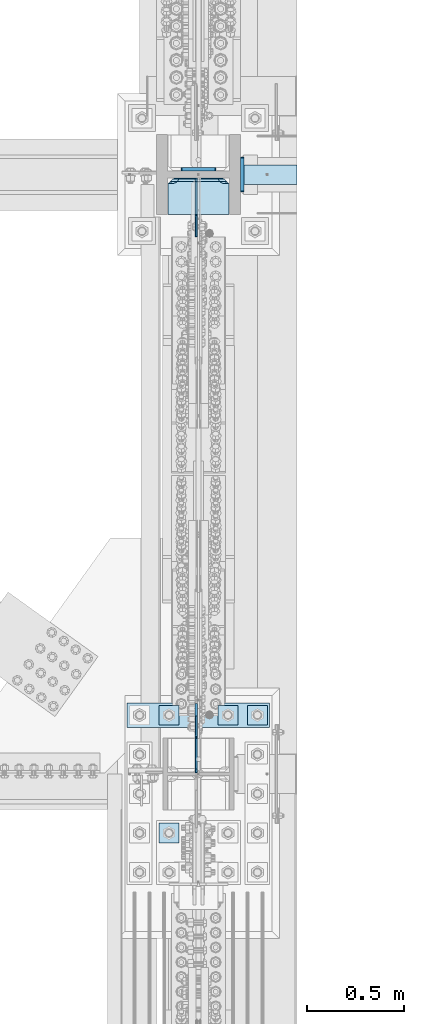
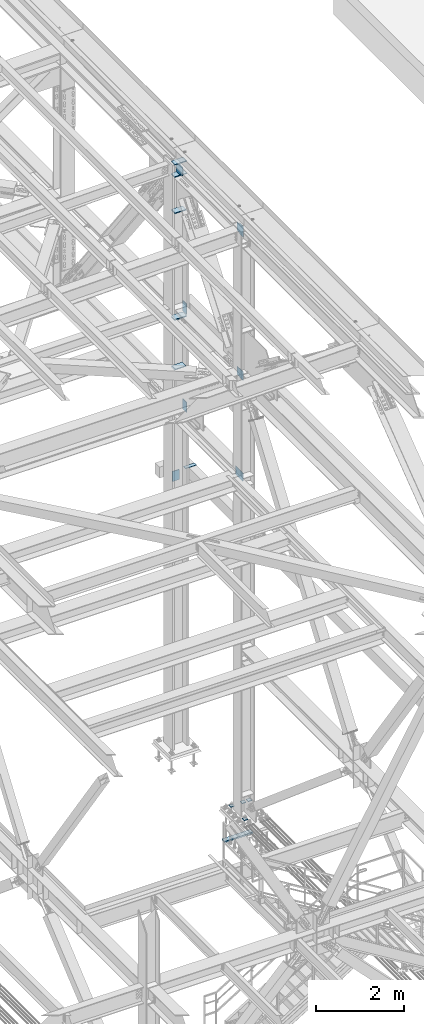
# One storey, part 3583 of 3843: 18 plates, 4 elements without a shape of their own.
"""IFC2X3 building model written with IfcOpenShell, lengths in millimetres."""

from ifc_helpers import new_model, si_unit, frame, origin_with_axes, place, context, subcontext, project, spatial, faceted_brep, material, type_object, element, aggregate, save


model = new_model("IFC2X3")

# Units and contexts
model_context = context("Model", 3, precision=1e-05, world=origin_with_axes())
body_context = subcontext(model_context, "Body", "Model", "MODEL_VIEW")
ifc_project = project(units=[si_unit("LENGTHUNIT", "METRE", prefix="MILLI"), si_unit("AREAUNIT", "SQUARE_METRE"), si_unit("VOLUMEUNIT", "CUBIC_METRE"), si_unit("MASSUNIT", "GRAM", prefix="KILO"), si_unit("TIMEUNIT", "SECOND"), si_unit("PLANEANGLEUNIT", "RADIAN"), si_unit("SOLIDANGLEUNIT", "STERADIAN"), si_unit("THERMODYNAMICTEMPERATUREUNIT", "DEGREE_CELSIUS"), si_unit("LUMINOUSINTENSITYUNIT", "LUMEN")], contexts=[model_context])

# Site, building, storey
site_placement = place(None, origin_with_axes())
site = spatial("IfcSite", under=ifc_project, at=site_placement, CompositionType="ELEMENT")
building_placement = place(site_placement, origin_with_axes())
building = spatial("IfcBuilding", under=site, at=building_placement, Name="Undefined", CompositionType="ELEMENT")
storey_placement = place(building_placement, origin_with_axes())
storey = spatial("IfcBuildingStorey", under=building, at=storey_placement, Name="Undefined", CompositionType="ELEMENT", Elevation=0.0)

# Assembly, plate
assembly_1_placement = place(storey_placement, origin_with_axes())
assembly_1 = element("IfcElementAssembly", 1, at=assembly_1_placement, inside=storey, Name="PLATE", AssemblyPlace="NOTDEFINED", PredefinedType="RIGID_FRAME")
ifc_material = material(Name="STEEL/A572-50")
plate_type_1 = type_object("IfcPlateType", PredefinedType="NOTDEFINED")
plate_1_placement = place(assembly_1_placement, frame((85866.287122492, 28663.8999999998, 37749.1625), z_axis=(0.0, 1.0, 0.0), x_axis=(1.0, 0.0, 0.0)))
plate_1 = element("IfcPlate", 2, at=plate_1_placement, type_object=plate_type_1, material=ifc_material, Name="PLATE", context=body_context, shape_type="Brep", body=[
    faceted_brep([(0.0, -4.76249999999709, 0.0), (-0.000122492027003318, -4.76249999999709, 101.599998474121), (-0.000122492027003318, 4.76249999999709, 101.599998474121), (0.0, 4.76249999999709, 0.0), (290.512755437681, -4.76249999999709, 101.599998474107), (290.512755437681, 4.76249999999709, 101.599998474107), (290.512877507994, -4.76249999999709, -2.91038304567337e-11), (290.512877507994, 4.76249999999709, -2.91038304567337e-11)], [[[0, 1, 2, 3]], [[1, 4, 5, 2]], [[4, 6, 7, 5]], [[6, 0, 3, 7]], [[5, 7, 3, 2]], [[6, 4, 1, 0]]]),
])
aggregate(assembly_1, [plate_1])

# Assembly, plates
assembly_2_placement = place(storey_placement, origin_with_axes())
assembly_2 = element("IfcElementAssembly", 3, at=assembly_2_placement, inside=storey, Name="COLUMN", AssemblyPlace="NOTDEFINED", PredefinedType="RIGID_FRAME")
plate_type_2 = type_object("IfcPlateType", PredefinedType="NOTDEFINED")
plate_2_placement = place(assembly_2_placement, frame((85739.2875, 28742.48125, 37733.2875), z_axis=(0.0, 0.0, -1.0), x_axis=(-1.0, 0.0, 0.0)))
plate_2 = element("IfcPlate", 4, at=plate_2_placement, type_object=plate_type_2, material=ifc_material, Name="PLATE", context=body_context, shape_type="Brep", body=[
    faceted_brep([(-8.22591685395256e-13, -9.52499999999854, 7.9375), (0.0, -9.52499999999418, 274.637500000004), (0.0, 9.52499999999418, 274.637500000004), (0.0, 9.52499999999418, 7.9375), (0.604206210686243, -9.52499999999418, 277.675049744401), (0.604206210686243, 9.52499999999418, 277.675049744401), (2.32483992433117, -9.52499999999418, 280.250160075673), (2.32483992433117, 9.52499999999418, 280.250160075673), (4.8999502555962, -9.52499999999418, 281.970793789311), (4.8999502555962, 9.52499999999418, 281.970793789311), (7.9375, -9.52499999999418, 282.575000000004), (7.9375, 9.52499999999418, 282.575000000004), (173.037499999991, -9.52499999999418, 282.575000000004), (173.037499999991, 9.52499999999418, 282.575000000004), (176.075049744395, -9.52499999999418, 281.970793789311), (176.075049744395, 9.52499999999418, 281.970793789311), (178.65016007566, -9.52499999999418, 280.250160075673), (178.65016007566, 9.52499999999418, 280.250160075673), (180.370793789305, -9.52499999999418, 277.675049744401), (180.370793789305, 9.52499999999418, 277.675049744401), (180.974999999991, -9.52499999999418, 274.637500000004), (180.974999999991, 9.52499999999418, 274.637500000004), (180.974999999991, -9.52499999999418, 7.93750000000728), (180.974999999991, 9.52499999999418, 7.93750000000728), (180.370793789305, -9.52499999999418, 4.89995025561075), (180.370793789305, 9.52499999999418, 4.89995025561075), (178.65016007566, -9.52499999999418, 2.32483992433845), (178.65016007566, 9.52499999999418, 2.32483992433845), (176.075049744395, -9.52499999999418, 0.604206210700795), (176.075049744395, 9.52499999999418, 0.604206210700795), (173.037500000006, -9.52499999999418, 7.27595761418343e-12), (173.037500000006, 9.52499999999418, 7.27595761418343e-12), (7.9375, -9.52499999999854, 0.0), (7.9375, 9.52499999999418, 0.0), (4.8999502555962, -9.52499999999418, 0.604206210693519), (4.8999502555962, 9.52499999999418, 0.604206210693519), (2.32483992433117, -9.52499999999418, 2.32483992433117), (2.32483992433117, 9.52499999999418, 2.32483992433117), (0.604206210686243, -9.52499999999418, 4.89995025560347), (0.604206210686243, 9.52499999999418, 4.89995025560347)], [[[0, 1, 2, 3]], [[1, 4, 5, 2]], [[4, 6, 7, 5]], [[6, 8, 9, 7]], [[8, 10, 11, 9]], [[10, 12, 13, 11]], [[12, 14, 15, 13]], [[14, 16, 17, 15]], [[16, 18, 19, 17]], [[18, 20, 21, 19]], [[20, 22, 23, 21]], [[22, 24, 25, 23]], [[24, 26, 27, 25]], [[26, 28, 29, 27]], [[28, 30, 31, 29]], [[30, 32, 33, 31]], [[32, 34, 35, 33]], [[34, 36, 37, 35]], [[36, 38, 39, 37]], [[38, 0, 3, 39]], [[5, 7, 9, 11, 13, 15, 17, 19, 21, 23, 25, 27, 29, 31, 33, 35, 37, 39, 3, 2]], [[38, 36, 34, 32, 30, 28, 26, 24, 22, 20, 18, 16, 14, 12, 10, 8, 6, 4, 1, 0]]]),
])
plate_3_placement = place(assembly_2_placement, frame((85875.8124999523, 28805.1875, 39619.2375), z_axis=(0.0, 0.0, -1.0), x_axis=(0.0, -1.0, 0.0)))
plate_3 = element("IfcPlate", 5, at=plate_3_placement, type_object=plate_type_2, material=ifc_material, Name="PLATE", context=body_context, shape_type="Brep", body=[
    faceted_brep([(-8.22591685395256e-13, -9.52499999999854, 7.9375), (0.0, -9.52499999999418, 274.637500000004), (0.0, 9.52499999999418, 274.637500000004), (0.0, 9.52499999999418, 7.9375), (0.604206210686243, -9.52499999999418, 277.675049744401), (0.604206210686243, 9.52499999999418, 277.675049744401), (2.32483992433117, -9.52499999999418, 280.250160075673), (2.32483992433117, 9.52499999999418, 280.250160075673), (4.8999502555962, -9.52499999999418, 281.970793789311), (4.8999502555962, 9.52499999999418, 281.970793789311), (7.9375, -9.52499999999418, 282.575000000004), (7.9375, 9.52499999999418, 282.575000000004), (173.037499999991, -9.52499999999418, 282.575000000004), (173.037499999991, 9.52499999999418, 282.575000000004), (176.075049744395, -9.52499999999418, 281.970793789311), (176.075049744395, 9.52499999999418, 281.970793789311), (178.65016007566, -9.52499999999418, 280.250160075673), (178.65016007566, 9.52499999999418, 280.250160075673), (180.370793789305, -9.52499999999418, 277.675049744401), (180.370793789305, 9.52499999999418, 277.675049744401), (180.974999999991, -9.52499999999418, 274.637500000004), (180.974999999991, 9.52499999999418, 274.637500000004), (180.974999999991, -9.52499999999418, 7.93750000000728), (180.974999999991, 9.52499999999418, 7.93750000000728), (180.370793789305, -9.52499999999418, 4.89995025561075), (180.370793789305, 9.52499999999418, 4.89995025561075), (178.65016007566, -9.52499999999418, 2.32483992433845), (178.65016007566, 9.52499999999418, 2.32483992433845), (176.075049744395, -9.52499999999418, 0.604206210700795), (176.075049744395, 9.52499999999418, 0.604206210700795), (173.037500000006, -9.52499999999418, 7.27595761418343e-12), (173.037500000006, 9.52499999999418, 7.27595761418343e-12), (7.9375, -9.52499999999854, 0.0), (7.9375, 9.52499999999418, 0.0), (4.8999502555962, -9.52499999999418, 0.604206210693519), (4.8999502555962, 9.52499999999418, 0.604206210693519), (2.32483992433117, -9.52499999999418, 2.32483992433117), (2.32483992433117, 9.52499999999418, 2.32483992433117), (0.604206210686243, -9.52499999999418, 4.89995025560347), (0.604206210686243, 9.52499999999418, 4.89995025560347)], [[[0, 1, 2, 3]], [[1, 4, 5, 2]], [[4, 6, 7, 5]], [[6, 8, 9, 7]], [[8, 10, 11, 9]], [[10, 12, 13, 11]], [[12, 14, 15, 13]], [[14, 16, 17, 15]], [[16, 18, 19, 17]], [[18, 20, 21, 19]], [[20, 22, 23, 21]], [[22, 24, 25, 23]], [[24, 26, 27, 25]], [[26, 28, 29, 27]], [[28, 30, 31, 29]], [[30, 32, 33, 31]], [[32, 34, 35, 33]], [[34, 36, 37, 35]], [[36, 38, 39, 37]], [[38, 0, 3, 39]], [[5, 7, 9, 11, 13, 15, 17, 19, 21, 23, 25, 27, 29, 31, 33, 35, 37, 39, 3, 2]], [[38, 36, 34, 32, 30, 28, 26, 24, 22, 20, 18, 16, 14, 12, 10, 8, 6, 4, 1, 0]]]),
])
plate_4_placement = place(assembly_2_placement, frame((85875.8124999523, 28805.1875, 42356.0875), z_axis=(0.0, 0.0, -1.0), x_axis=(0.0, -1.0, 0.0)))
plate_4 = element("IfcPlate", 6, at=plate_4_placement, type_object=plate_type_2, material=ifc_material, Name="PLATE", context=body_context, shape_type="Brep", body=[
    faceted_brep([(-8.22591685395256e-13, -9.52499999999854, 7.9375), (0.0, -9.52499999999418, 274.637500000004), (0.0, 9.52499999999418, 274.637500000004), (0.0, 9.52499999999418, 7.9375), (0.604206210686243, -9.52499999999418, 277.675049744401), (0.604206210686243, 9.52499999999418, 277.675049744401), (2.32483992433117, -9.52499999999418, 280.250160075673), (2.32483992433117, 9.52499999999418, 280.250160075673), (4.8999502555962, -9.52499999999418, 281.970793789311), (4.8999502555962, 9.52499999999418, 281.970793789311), (7.9375, -9.52499999999418, 282.575000000004), (7.9375, 9.52499999999418, 282.575000000004), (173.037499999991, -9.52499999999418, 282.575000000004), (173.037499999991, 9.52499999999418, 282.575000000004), (176.075049744395, -9.52499999999418, 281.970793789311), (176.075049744395, 9.52499999999418, 281.970793789311), (178.65016007566, -9.52499999999418, 280.250160075673), (178.65016007566, 9.52499999999418, 280.250160075673), (180.370793789305, -9.52499999999418, 277.675049744401), (180.370793789305, 9.52499999999418, 277.675049744401), (180.974999999991, -9.52499999999418, 274.637500000004), (180.974999999991, 9.52499999999418, 274.637500000004), (180.974999999991, -9.52499999999418, 7.93750000000728), (180.974999999991, 9.52499999999418, 7.93750000000728), (180.370793789305, -9.52499999999418, 4.89995025561075), (180.370793789305, 9.52499999999418, 4.89995025561075), (178.65016007566, -9.52499999999418, 2.32483992433845), (178.65016007566, 9.52499999999418, 2.32483992433845), (176.075049744395, -9.52499999999418, 0.604206210700795), (176.075049744395, 9.52499999999418, 0.604206210700795), (173.037500000006, -9.52499999999418, 7.27595761418343e-12), (173.037500000006, 9.52499999999418, 7.27595761418343e-12), (7.9375, -9.52499999999854, 0.0), (7.9375, 9.52499999999418, 0.0), (4.8999502555962, -9.52499999999418, 0.604206210693519), (4.8999502555962, 9.52499999999418, 0.604206210693519), (2.32483992433117, -9.52499999999418, 2.32483992433117), (2.32483992433117, 9.52499999999418, 2.32483992433117), (0.604206210686243, -9.52499999999418, 4.89995025560347), (0.604206210686243, 9.52499999999418, 4.89995025560347)], [[[0, 1, 2, 3]], [[1, 4, 5, 2]], [[4, 6, 7, 5]], [[6, 8, 9, 7]], [[8, 10, 11, 9]], [[10, 12, 13, 11]], [[12, 14, 15, 13]], [[14, 16, 17, 15]], [[16, 18, 19, 17]], [[18, 20, 21, 19]], [[20, 22, 23, 21]], [[22, 24, 25, 23]], [[24, 26, 27, 25]], [[26, 28, 29, 27]], [[28, 30, 31, 29]], [[30, 32, 33, 31]], [[32, 34, 35, 33]], [[34, 36, 37, 35]], [[36, 38, 39, 37]], [[38, 0, 3, 39]], [[5, 7, 9, 11, 13, 15, 17, 19, 21, 23, 25, 27, 29, 31, 33, 35, 37, 39, 3, 2]], [[38, 36, 34, 32, 30, 28, 26, 24, 22, 20, 18, 16, 14, 12, 10, 8, 6, 4, 1, 0]]]),
])
plate_type_3 = type_object("IfcPlateType", PredefinedType="NOTDEFINED")
plate_5_placement = place(assembly_2_placement, frame((85809.1375, 28509.1188, 40731.5069065225), z_axis=(-1.0, 0.0, 0.0), x_axis=(0.0, 1.0, 0.0)))
plate_5 = element("IfcPlate", 7, at=plate_5_placement, type_object=plate_type_3, material=ifc_material, Name="PLATE", context=body_context, shape_type="Brep", body=[
    faceted_brep([(0.0, -12.6999999999971, 302.835803430513), (0.0, 12.6999999999971, 317.500500047681), (0.0, 12.6999999999971, 3.17549995231093), (0.0, -12.6999999999971, 17.8401965694793), (158.749449952324, 12.6999999999971, 317.500500047681), (184.150200047683, 12.6999999999971, 292.099749952322), (184.150200047683, 12.6999999999971, 28.575250047681), (158.750449952313, 12.6999999999971, 3.17549995231093), (171.450325014754, -9.29682918828621, 15.8753750147443), (169.485503430507, -12.6999999999971, 17.8401965694793), (169.485503430507, -12.6999999999971, 302.835803430513), (171.449825014755, -9.29769521368144, 304.800124985253)], [[[0, 1, 2, 3]], [[4, 5, 6, 7, 2, 1]], [[3, 2, 7, 8, 9]], [[0, 3, 9, 10]], [[4, 1, 0, 10, 11]], [[4, 11, 5]], [[10, 9, 8, 6, 5, 11]], [[7, 6, 8]]]),
])
plate_6_placement = place(assembly_2_placement, frame((85490.05, 28509.11875, 46101.0), z_axis=(1.0, 0.0, 0.0), x_axis=(0.0, 1.0, 0.0)))
plate_6 = element("IfcPlate", 8, at=plate_6_placement, type_object=plate_type_3, material=ifc_material, Name="PLATE", context=body_context, shape_type="Brep", body=[
    faceted_brep([(171.462145952202, 9.27600831387099, 50.4083462814015), (169.485303430512, 12.6999999999971, 48.4315037597116), (169.485303430512, 12.6999999999971, 269.068496240288), (171.462145952202, 9.27600831387099, 267.091653718599), (178.985404100069, -3.75465703669033, 263.258362229142), (184.150000047688, -12.6999999999971, 262.440370590484), (184.150000047688, -12.6999999999971, 55.0596294095158), (178.985404100069, -3.75465703669033, 54.2416377708578), (0.0, -12.6999999999971, 0.0), (0.0, -12.7000000020344, 317.500000001608), (0.0, 12.6999999977998, 317.500000001586), (0.0, 12.6999999999971, 0.0), (160.33750076294, -12.6999999999971, 317.5), (160.33750076294, 12.6999999999971, 317.5), (160.33750076294, -12.6999999999971, 288.924999237061), (160.33750076294, 12.6999999999971, 288.924999237061), (161.658362992082, -12.6999999999971, 280.585403337129), (161.658362992082, 12.6999999999971, 280.585403337129), (165.491654481539, -12.6999999999971, 273.062145189266), (165.491654481539, 12.6999999999971, 273.062145189266), (171.462145952202, -12.6999999999971, 267.091653718599), (178.985404100069, -12.6999999999971, 263.258362229142), (178.985404100069, -12.6999999999971, 54.2416377708578), (171.462145952202, -12.6999999999971, 50.4083462814015), (165.491654481539, -12.6999999999971, 44.4378548107343), (165.491654481539, 12.6999999999971, 44.4378548107343), (161.658362992082, -12.6999999999971, 36.9145966628712), (161.658362992082, 12.6999999999971, 36.9145966628712), (160.33750076294, -12.6999999999971, 28.5750007629395), (160.33750076294, 12.6999999999971, 28.5750007629395), (160.33750076294, -12.6999999999971, 0.0), (160.33750076294, 12.6999999999971, 0.0)], [[[0, 1, 2, 3, 4, 5, 6, 7]], [[8, 9, 10, 11]], [[9, 12, 13, 10]], [[12, 14, 15, 13]], [[14, 16, 17, 15]], [[16, 18, 19, 17]], [[19, 18, 20, 3, 2]], [[20, 21, 4, 3]], [[21, 5, 4]], [[22, 7, 6]], [[22, 23, 0, 7]], [[23, 24, 25, 1, 0]], [[24, 26, 27, 25]], [[26, 28, 29, 27]], [[28, 30, 31, 29]], [[30, 8, 11, 31]], [[25, 27, 29, 31, 11, 10, 13, 15, 17, 19, 2, 1]], [[30, 28, 26, 24, 23, 22, 6, 5, 21, 20, 18, 16, 14, 12, 9, 8]]]),
])
plate_7_placement = place(assembly_2_placement, frame((85809.1375, 28509.1188, 45089.9791498074), z_axis=(-1.0, 0.0, 0.0), x_axis=(0.0, 1.0, 0.0)))
plate_7 = element("IfcPlate", 9, at=plate_7_placement, type_object=plate_type_3, material=ifc_material, Name="PLATE", context=body_context, shape_type="Brep", body=[
    faceted_brep([(0.0, -12.6999999999971, 302.835803430513), (0.0, 12.6999999999971, 317.500500047681), (0.0, 12.6999999999971, 3.17549995231093), (0.0, -12.6999999999971, 17.8401965694793), (158.749449952324, 12.6999999999971, 317.500500047681), (184.150200047683, 12.6999999999971, 292.099749952322), (184.150200047683, 12.6999999999971, 28.575250047681), (158.750449952313, 12.6999999999971, 3.17549995231093), (171.450325014754, -9.29682918828621, 15.8753750147443), (169.485503430507, -12.6999999999971, 17.8401965694793), (169.485503430507, -12.6999999999971, 302.835803430513), (171.449825014755, -9.29769521368144, 304.800124985253)], [[[0, 1, 2, 3]], [[4, 5, 6, 7, 2, 1]], [[3, 2, 7, 8, 9]], [[0, 3, 9, 10]], [[4, 1, 0, 10, 11]], [[4, 11, 5]], [[10, 9, 8, 6, 5, 11]], [[7, 6, 8]]]),
])
plate_8_placement = place(assembly_2_placement, frame((85490.05, 28509.11875, 46443.9), z_axis=(1.0, 0.0, 0.0), x_axis=(0.0, 1.0, 0.0)))
plate_8 = element("IfcPlate", 10, at=plate_8_placement, type_object=plate_type_3, material=ifc_material, Name="PLATE", context=body_context, shape_type="Brep", body=[
    faceted_brep([(171.462145952202, 9.27600831387099, 50.4083462814015), (169.485303430512, 12.6999999999971, 48.4315037597116), (169.485303430512, 12.6999999999971, 269.068496240288), (171.462145952202, 9.27600831387099, 267.091653718599), (178.985404100069, -3.75465703669033, 263.258362229142), (184.150000047688, -12.6999999999971, 262.440370590484), (184.150000047688, -12.6999999999971, 55.0596294095158), (178.985404100069, -3.75465703669033, 54.2416377708578), (0.0, -12.6999999999971, 0.0), (0.0, -12.7000000020344, 317.500000001608), (0.0, 12.6999999977998, 317.500000001586), (0.0, 12.6999999999971, 0.0), (160.33750076294, -12.6999999999971, 317.5), (160.33750076294, 12.6999999999971, 317.5), (160.33750076294, -12.6999999999971, 288.924999237061), (160.33750076294, 12.6999999999971, 288.924999237061), (161.658362992082, -12.6999999999971, 280.585403337129), (161.658362992082, 12.6999999999971, 280.585403337129), (165.491654481539, -12.6999999999971, 273.062145189266), (165.491654481539, 12.6999999999971, 273.062145189266), (171.462145952202, -12.6999999999971, 267.091653718599), (178.985404100069, -12.6999999999971, 263.258362229142), (178.985404100069, -12.6999999999971, 54.2416377708578), (171.462145952202, -12.6999999999971, 50.4083462814015), (165.491654481539, -12.6999999999971, 44.4378548107343), (165.491654481539, 12.6999999999971, 44.4378548107343), (161.658362992082, -12.6999999999971, 36.9145966628712), (161.658362992082, 12.6999999999971, 36.9145966628712), (160.33750076294, -12.6999999999971, 28.5750007629395), (160.33750076294, 12.6999999999971, 28.5750007629395), (160.33750076294, -12.6999999999971, 0.0), (160.33750076294, 12.6999999999971, 0.0)], [[[0, 1, 2, 3, 4, 5, 6, 7]], [[8, 9, 10, 11]], [[9, 12, 13, 10]], [[12, 14, 15, 13]], [[14, 16, 17, 15]], [[16, 18, 19, 17]], [[19, 18, 20, 3, 2]], [[20, 21, 4, 3]], [[21, 5, 4]], [[22, 7, 6]], [[22, 23, 0, 7]], [[23, 24, 25, 1, 0]], [[24, 26, 27, 25]], [[26, 28, 29, 27]], [[28, 30, 31, 29]], [[30, 8, 11, 31]], [[25, 27, 29, 31, 11, 10, 13, 15, 17, 19, 2, 1]], [[30, 28, 26, 24, 23, 22, 6, 5, 21, 20, 18, 16, 14, 12, 9, 8]]]),
])
plate_type_4 = type_object("IfcPlateType", PredefinedType="NOTDEFINED")
plate_9_placement = place(assembly_2_placement, frame((85490.05, 28512.29375, 42116.375), z_axis=(1.0, 0.0, 0.0), x_axis=(0.0, 1.0, 0.0)))
plate_9 = element("IfcPlate", 11, at=plate_9_placement, type_object=plate_type_4, material=ifc_material, Name="PLATE", context=body_context, shape_type="Brep", body=[
    faceted_brep([(0.0, -15.875, 0.0), (0.0, -15.875, 317.5), (0.0, 15.875, 317.5), (0.0, 15.875, 0.0), (150.812498468062, -15.8749999998181, 317.5), (150.812498468251, 15.8750000001601, 317.5), (184.149999995119, -15.8749999997817, 284.162498474121), (184.149999995323, 15.8750000001965, 284.162498474121), (184.150000002424, -15.8749999997744, 33.3375015258789), (184.150000002628, 15.8750000001892, 33.3375015258789), (150.812498477302, -15.8749999998181, 0.0), (150.812498477491, 15.8750000001528, 0.0)], [[[0, 1, 2, 3]], [[1, 4, 5, 2]], [[4, 6, 7, 5]], [[6, 8, 9, 7]], [[8, 10, 11, 9]], [[10, 0, 3, 11]], [[5, 7, 9, 11, 3, 2]], [[10, 8, 6, 4, 1, 0]]]),
])

assembly_3_placement = place(storey_placement, origin_with_axes())
assembly_3 = element("IfcElementAssembly", 12, at=assembly_3_placement, inside=storey, Name="TEMPLATE", AssemblyPlace="NOTDEFINED", PredefinedType="RIGID_FRAME")
plate_type_5 = type_object("IfcPlateType", PredefinedType="NOTDEFINED")
plate_10_placement = place(assembly_3_placement, frame((85902.8, 25971.5, 30143.45), z_axis=(0.0, -1.0, 0.0), x_axis=(1.0, 0.0, 0.0)))
plate_10 = element("IfcPlate", 13, at=plate_10_placement, type_object=plate_type_5, material=ifc_material, Name="Washer Plate", context=body_context, shape_type="Brep", body=[
    faceted_brep([(0.0, -6.3499999046162, 0.0), (-1.67347025126219e-10, -6.35000000000582, 101.600000000151), (-1.67347025126219e-10, 6.35000000000582, 101.600000000151), (7.27595761418343e-12, 6.3499999046162, 0.0), (101.599998474121, -6.34999999999854, 101.599998474121), (101.599998474121, 6.34999999999854, 101.599998474121), (101.6, -6.34999999999854, 0.0), (101.6, 6.34999999999854, 0.0)], [[[0, 1, 2, 3]], [[1, 4, 5, 2]], [[4, 6, 7, 5]], [[6, 0, 3, 7]], [[5, 7, 3, 2]], [[6, 4, 1, 0]]]),
])
plate_11_placement = place(assembly_3_placement, frame((85750.4, 25971.5, 30143.45), z_axis=(0.0, -1.0, 0.0), x_axis=(1.0, 0.0, 0.0)))
plate_11 = element("IfcPlate", 14, at=plate_11_placement, type_object=plate_type_5, material=ifc_material, Name="Washer Plate", context=body_context, shape_type="Brep", body=[
    faceted_brep([(0.0, -6.3499999046162, 0.0), (-1.67347025126219e-10, -6.35000000000582, 101.600000000151), (-1.67347025126219e-10, 6.35000000000582, 101.600000000151), (7.27595761418343e-12, 6.3499999046162, 0.0), (101.599998474121, -6.34999999999854, 101.599998474121), (101.599998474121, 6.34999999999854, 101.599998474121), (101.6, -6.34999999999854, 0.0), (101.6, 6.34999999999854, 0.0)], [[[0, 1, 2, 3]], [[1, 4, 5, 2]], [[4, 6, 7, 5]], [[6, 0, 3, 7]], [[5, 7, 3, 2]], [[6, 4, 1, 0]]]),
])
plate_12_placement = place(assembly_3_placement, frame((85445.6, 25361.9, 30143.45), z_axis=(0.0, -1.0, 0.0), x_axis=(1.0, 0.0, 0.0)))
plate_12 = element("IfcPlate", 15, at=plate_12_placement, type_object=plate_type_5, material=ifc_material, Name="Washer Plate", context=body_context, shape_type="Brep", body=[
    faceted_brep([(0.0, -6.3499999046162, 0.0), (-1.67347025126219e-10, -6.35000000000582, 101.600000000151), (-1.67347025126219e-10, 6.35000000000582, 101.600000000151), (7.27595761418343e-12, 6.3499999046162, 0.0), (101.599998474121, -6.34999999999854, 101.599998474121), (101.599998474121, 6.34999999999854, 101.599998474121), (101.6, -6.34999999999854, 0.0), (101.6, 6.34999999999854, 0.0)], [[[0, 1, 2, 3]], [[1, 4, 5, 2]], [[4, 6, 7, 5]], [[6, 0, 3, 7]], [[5, 7, 3, 2]], [[6, 4, 1, 0]]]),
])
plate_13_placement = place(assembly_3_placement, frame((85445.6, 25971.5, 30143.45), z_axis=(0.0, -1.0, 0.0), x_axis=(1.0, 0.0, 0.0)))
plate_13 = element("IfcPlate", 16, at=plate_13_placement, type_object=plate_type_5, material=ifc_material, Name="Washer Plate", context=body_context, shape_type="Brep", body=[
    faceted_brep([(0.0, -6.3499999046162, 0.0), (-1.67347025126219e-10, -6.35000000000582, 101.600000000151), (-1.67347025126219e-10, 6.35000000000582, 101.600000000151), (7.27595761418343e-12, 6.3499999046162, 0.0), (101.599998474121, -6.34999999999854, 101.599998474121), (101.599998474121, 6.34999999999854, 101.599998474121), (101.6, -6.34999999999854, 0.0), (101.6, 6.34999999999854, 0.0)], [[[0, 1, 2, 3]], [[1, 4, 5, 2]], [[4, 6, 7, 5]], [[6, 0, 3, 7]], [[5, 7, 3, 2]], [[6, 4, 1, 0]]]),
])

assembly_4_placement = place(storey_placement, origin_with_axes())
assembly_4 = element("IfcElementAssembly", 17, at=assembly_4_placement, inside=storey, Name="COLUMN", AssemblyPlace="NOTDEFINED", PredefinedType="RIGID_FRAME")
plate_type_6 = type_object("IfcPlateType", PredefinedType="NOTDEFINED")
plate_14_placement = place(assembly_4_placement, frame((85637.6870000839, 25623.04375, 42138.6), z_axis=(0.0, 0.707106781186548, 0.707106781186548), x_axis=(5.70000238222118e-08, 0.707106781186546, -0.707106781186546)))
plate_14 = element("IfcPlate", 18, at=plate_14_placement, type_object=plate_type_6, material=ifc_material, Name="PLATE", context=body_context, shape_type="Brep", body=[
    faceted_brep([(0.0, -4.76249999999709, 0.0), (-152.664354057442, -4.76249999999709, 152.66435405743), (-152.664354057442, 4.76249999999709, 152.66435405743), (0.0, 4.76249999999709, 0.0), (-152.664354057319, -4.76249999999709, 179.605122420653), (-152.664354057319, 4.76249999999709, 179.605122420653), (-40.4111524084819, -4.76249999999709, 291.858323799781), (-40.4111524084819, 4.76249999999709, 291.858323799781), (-36.2909759403356, -4.76249999999709, 289.105309899307), (-36.2909759403356, 4.76249999999709, 289.105309899307), (-31.4308964223037, -4.76249999999709, 288.138579976723), (-31.4308964223037, 4.76249999999709, 288.138579976723), (-26.5708169042682, -4.76249999999709, 289.105309899314), (-26.5708169042682, 4.76249999999709, 289.105309899314), (-22.4506404361291, -4.76249999999709, 291.858323799781), (-22.4506404361291, 4.76249999999709, 291.858323799781), (49.9526746753309, -4.76249999999709, 364.261638911237), (49.9526746753309, 4.76249999999709, 364.261638911237), (211.597284853791, -4.76249999999709, 202.61702873277), (211.597284853791, 4.76249999999709, 202.61702873277), (139.193969742335, -4.76249999999709, 130.213713621313), (139.193969742335, 4.76249999999709, 130.213713621313), (136.440955841861, -4.76249999999709, 126.093537153181), (136.440955841861, 4.76249999999709, 126.093537153181), (135.474225919277, -4.76249999999709, 121.233457635142), (135.474225919277, 4.76249999999709, 121.233457635142), (136.440955841865, -4.76249999999709, 116.373378117103), (136.440955841865, 4.76249999999709, 116.373378117103), (139.193969877184, -4.76249999999709, 112.253201514119), (139.193969877184, 4.76249999999709, 112.253201514119), (26.9407683631998, -4.76249999999709, 1.30967237055302e-10), (26.9407683631998, 4.76249999999709, 1.30967237055302e-10)], [[[0, 1, 2, 3]], [[1, 4, 5, 2]], [[4, 6, 7, 5]], [[6, 8, 9, 7]], [[8, 10, 11, 9]], [[10, 12, 13, 11]], [[12, 14, 15, 13]], [[14, 16, 17, 15]], [[16, 18, 19, 17]], [[18, 20, 21, 19]], [[20, 22, 23, 21]], [[22, 24, 25, 23]], [[24, 26, 27, 25]], [[26, 28, 29, 27]], [[28, 30, 31, 29]], [[30, 0, 3, 31]], [[5, 7, 9, 11, 13, 15, 17, 19, 21, 23, 25, 27, 29, 31, 3, 2]], [[30, 28, 26, 24, 22, 20, 18, 16, 14, 12, 10, 8, 6, 4, 1, 0]]]),
])
plate_type_7 = type_object("IfcPlateType", PredefinedType="NOTDEFINED")
plate_15_placement = place(assembly_4_placement, frame((85636.1, 25623.04375, 39331.9), z_axis=(0.0, 0.707106781186548, 0.707106781186548), x_axis=(5.70000238222118e-08, 0.707106781186546, -0.707106781186546)))
plate_15 = element("IfcPlate", 19, at=plate_15_placement, type_object=plate_type_7, material=ifc_material, Name="PLATE", context=body_context, shape_type="Brep", body=[
    faceted_brep([(0.0, -6.3499999046162, 0.0), (-134.703841815397, -6.35000000000582, 134.703841815395), (-134.703841815397, 6.35000000000582, 134.703841815395), (7.27595761418343e-12, 6.3499999046162, 0.0), (-134.703841815259, -6.35000000000582, 161.644610178604), (-134.703841815259, 6.35000000000582, 161.644610178604), (103.834211404464, -6.35000000000582, 400.182663398424), (103.834211404464, 6.35000000000582, 400.182663398424), (265.478821582976, -6.35000000000582, 238.538053219985), (265.478821582976, 6.35000000000582, 238.538053219985), (26.9407683632217, -6.34999999999854, 1.30967237055302e-10), (26.9407683632217, 6.34999999999854, 1.30967237055302e-10)], [[[0, 1, 2, 3]], [[1, 4, 5, 2]], [[4, 6, 7, 5]], [[6, 8, 9, 7]], [[8, 10, 11, 9]], [[10, 0, 3, 11]], [[5, 7, 9, 11, 3, 2]], [[10, 8, 6, 4, 1, 0]]]),
])

# Plate
plate_type_8 = type_object("IfcPlateType", PredefinedType="NOTDEFINED")
plate_16_placement = place(assembly_2_placement, frame((85636.8932500839, 28696.44375, 46132.75), z_axis=(0.0, -0.707106781186682, 0.707106781186413), x_axis=(0.0, -0.707106781186548, -0.707106781186548)))
plate_16 = element("IfcPlate", 20, at=plate_16_placement, type_object=plate_type_8, material=ifc_material, Name="PLATE", context=body_context, shape_type="Brep", body=[
    faceted_brep([(0.0, -4.76249999999709, 0.0), (-197.565634662584, -4.76249999999709, 197.565634662576), (-197.565634662584, 4.76249999999709, 197.565634662576), (0.0, 4.76249999999709, 0.0), (-197.565634662438, -4.76249999999709, 224.5064030258), (-197.565634662438, 4.76249999999709, 224.5064030258), (-78.5772410576174, -4.76249999999709, 343.49479663061), (-78.5772410576174, 4.76249999999709, 343.49479663061), (-60.6167286807176, -4.76249999999709, 325.534284253703), (-60.6167286807176, 4.76249999999709, 325.534284253703), (-56.4965522125713, -4.76249999999709, 322.781270353233), (-56.4965522125713, 4.76249999999709, 322.781270353233), (-51.6364726945467, -4.76249999999709, 321.814540430652), (-51.6364726945467, 4.76249999999709, 321.814540430652), (-46.7763931765076, -4.76249999999709, 322.781270353233), (-46.7763931765076, 4.76249999999709, 322.781270353233), (-42.6562167083612, -4.76249999999709, 325.53428425371), (-42.6562167083612, 4.76249999999709, 325.53428425371), (29.7470984030952, -4.76249999999709, 397.937599365167), (29.7470984030952, 4.76249999999709, 397.937599365167), (200.371964702586, -4.76249999999709, 227.312733065672), (200.371964702586, 4.76249999999709, 227.312733065672), (127.96864959113, -4.76249999999709, 154.909417954215), (127.96864959113, 4.76249999999709, 154.909417954215), (125.215635690656, -4.76249999999709, 150.789241486073), (125.215635690656, 4.76249999999709, 150.789241486073), (124.248905768072, -4.76249999999709, 145.929161968041), (124.248905768072, 4.76249999999709, 145.929161968041), (125.215635690649, -4.76249999999709, 141.069082450005), (125.215635690649, 4.76249999999709, 141.069082450005), (127.96864959113, -4.76249999999709, 136.948905981862), (127.96864959113, 4.76249999999709, 136.948905981862), (145.929161969376, -4.76249999999709, 118.988393606342), (145.929161969376, 4.76249999999709, 118.988393606342), (26.9407683631998, -4.76249999999709, 1.30967237055302e-10), (26.9407683631998, 4.76249999999709, 1.30967237055302e-10)], [[[0, 1, 2, 3]], [[1, 4, 5, 2]], [[4, 6, 7, 5]], [[6, 8, 9, 7]], [[8, 10, 11, 9]], [[10, 12, 13, 11]], [[12, 14, 15, 13]], [[14, 16, 17, 15]], [[16, 18, 19, 17]], [[18, 20, 21, 19]], [[20, 22, 23, 21]], [[22, 24, 25, 23]], [[24, 26, 27, 25]], [[26, 28, 29, 27]], [[28, 30, 31, 29]], [[30, 32, 33, 31]], [[32, 34, 35, 33]], [[34, 0, 3, 35]], [[5, 7, 9, 11, 13, 15, 17, 19, 21, 23, 25, 27, 29, 31, 33, 35, 3, 2]], [[34, 32, 30, 28, 26, 24, 22, 20, 18, 16, 14, 12, 10, 8, 6, 4, 1, 0]]]),
])

aggregate(assembly_2, [plate_2, plate_3, plate_4, plate_5, plate_6, plate_7, plate_8, plate_16, plate_9])

plate_type_9 = type_object("IfcPlateType", PredefinedType="NOTDEFINED")
plate_17_placement = place(assembly_4_placement, frame((85636.8932500839, 25623.04375, 46135.925), z_axis=(0.0, 0.707106781186548, 0.707106781186548), x_axis=(5.70000238222118e-08, 0.707106781186546, -0.707106781186546)))
plate_17 = element("IfcPlate", 21, at=plate_17_placement, type_object=plate_type_9, material=ifc_material, Name="PLATE", context=body_context, shape_type="Brep", body=[
    faceted_brep([(0.0, -4.76249999999709, 0.0), (-193.075506602067, -4.76249999999709, 193.075506602065), (-193.075506602067, 4.76249999999709, 193.075506602065), (0.0, 4.76249999999709, 0.0), (-193.07550660207, -4.76249999999709, 220.016274965135), (-193.07550660207, 4.76249999999709, 220.016274965135), (-80.8223050892429, -4.76249999999709, 332.269476477966), (-80.8223050892429, 4.76249999999709, 332.269476477966), (-65.1068567426028, -4.76249999999709, 316.554028131315), (-65.1068567426028, 4.76249999999709, 316.554028131315), (-60.98668027446, -4.76249999999709, 313.801014230849), (-60.98668027446, 4.76249999999709, 313.801014230849), (-56.1266007564245, -4.76249999999709, 312.834284308265), (-56.1266007564245, 4.76249999999709, 312.834284308265), (-51.2665212383927, -4.76249999999709, 313.801014230856), (-51.2665212383927, 4.76249999999709, 313.801014230856), (-47.1463447702463, -4.76249999999709, 316.554028131315), (-47.1463447702463, 4.76249999999709, 316.554028131315), (25.2569703403806, -4.76249999999709, 388.957343241957), (25.2569703403806, 4.76249999999709, 388.957343241957), (195.881836639868, -4.76249999999709, 218.332476942451), (195.881836639868, 4.76249999999709, 218.332476942451), (123.478521529252, -4.76249999999709, 145.929161831831), (123.478521529252, 4.76249999999709, 145.929161831831), (120.725507628778, -4.76249999999709, 141.808985363692), (120.725507628778, 4.76249999999709, 141.808985363692), (119.758777706191, -4.76249999999709, 136.948905845653), (119.758777706191, 4.76249999999709, 136.948905845653), (120.725507628778, -4.76249999999709, 132.088826327621), (120.725507628778, 4.76249999999709, 132.088826327621), (123.478521529249, -4.76249999999709, 127.968649859482), (123.478521529249, 4.76249999999709, 127.968649859482), (139.193969877184, -4.76249999999709, 112.253201514119), (139.193969877184, 4.76249999999709, 112.253201514119), (26.9407683631998, -4.76249999999709, 1.30967237055302e-10), (26.9407683631998, 4.76249999999709, 1.30967237055302e-10)], [[[0, 1, 2, 3]], [[1, 4, 5, 2]], [[4, 6, 7, 5]], [[6, 8, 9, 7]], [[8, 10, 11, 9]], [[10, 12, 13, 11]], [[12, 14, 15, 13]], [[14, 16, 17, 15]], [[16, 18, 19, 17]], [[18, 20, 21, 19]], [[20, 22, 23, 21]], [[22, 24, 25, 23]], [[24, 26, 27, 25]], [[26, 28, 29, 27]], [[28, 30, 31, 29]], [[30, 32, 33, 31]], [[32, 34, 35, 33]], [[34, 0, 3, 35]], [[5, 7, 9, 11, 13, 15, 17, 19, 21, 23, 25, 27, 29, 31, 33, 35, 3, 2]], [[34, 32, 30, 28, 26, 24, 22, 20, 18, 16, 14, 12, 10, 8, 6, 4, 1, 0]]]),
])

aggregate(assembly_4, [plate_14, plate_17, plate_15])

plate_type_10 = type_object("IfcPlateType", PredefinedType="NOTDEFINED")
plate_18_placement = place(assembly_3_placement, frame((85280.5, 25984.2, 29241.75), z_axis=(0.0, -1.0, 0.0), x_axis=(1.0, 0.0, 0.0)))
plate_18 = element("IfcPlate", 22, at=plate_18_placement, type_object=plate_type_10, material=ifc_material, Name="PLATE", context=body_context, shape_type="Brep", body=[
    faceted_brep([(0.0, -19.0500000000029, 0.0), (0.0, -19.0499999999993, 127.0), (0.0, 19.0499999999993, 127.0), (0.0, 19.0500000000029, 0.0), (736.599975585938, -19.0499999999993, 127.0), (736.599975585938, 19.0499999999993, 127.0), (736.599975585938, -19.0499999999993, 0.0), (736.599975585938, 19.0499999999993, 0.0)], [[[0, 1, 2, 3]], [[1, 4, 5, 2]], [[4, 6, 7, 5]], [[6, 0, 3, 7]], [[5, 7, 3, 2]], [[6, 4, 1, 0]]]),
])

aggregate(assembly_3, [plate_18, plate_10, plate_11, plate_12, plate_13])

save(model, "model.ifc")
